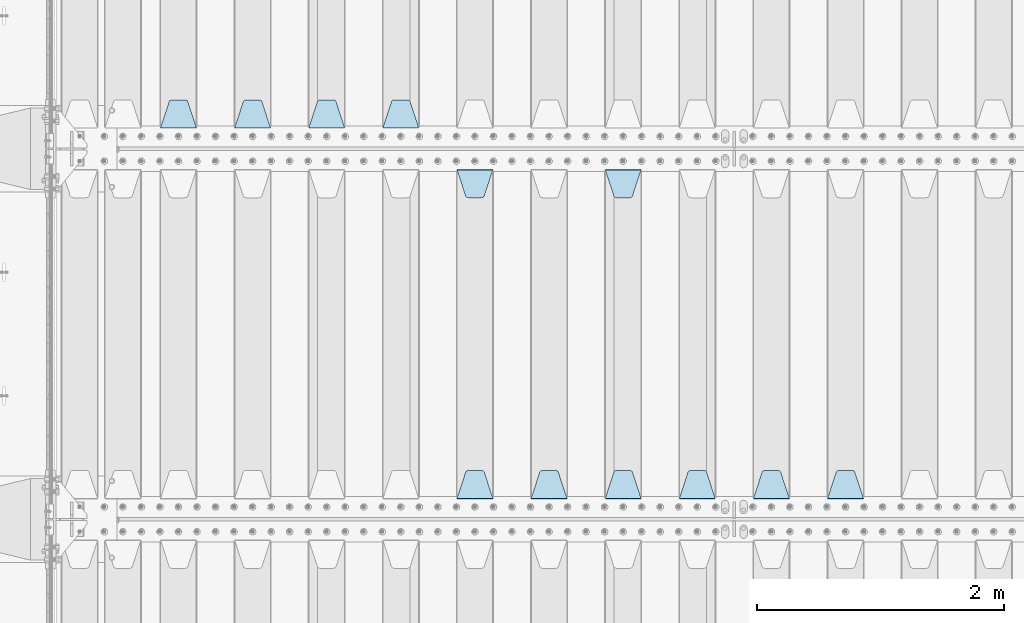
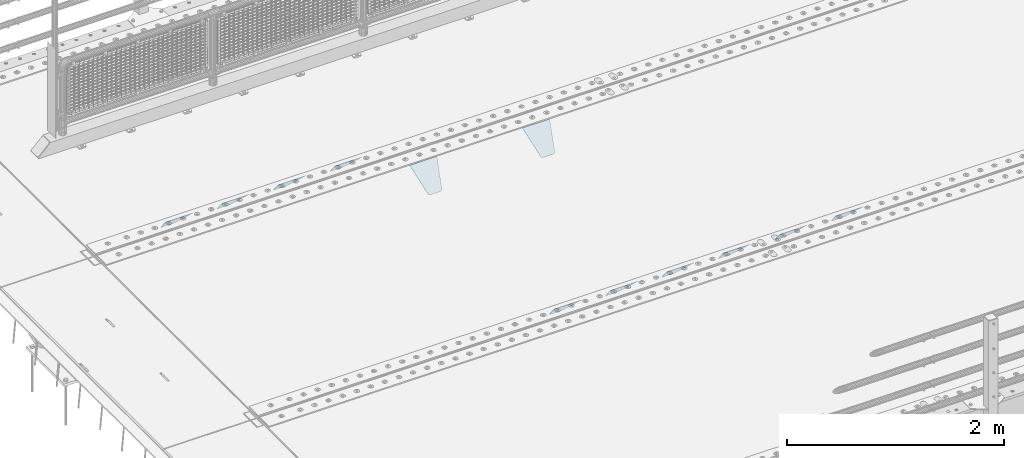
# One storey, part 201 of 247: 12 plates.
"""IFC2X3 building model written with IfcOpenShell, lengths in millimetres."""

from ifc_helpers import new_model, si_unit, frame, origin_with_axes, place, context, subcontext, project, spatial, faceted_brep, material, type_object, element, save


model = new_model("IFC2X3")

# Units and contexts
model_context = context("Model", 3, precision=1e-05, world=origin_with_axes())
body_context = subcontext(model_context, "Body", "Model", "MODEL_VIEW")
ifc_project = project(units=[si_unit("LENGTHUNIT", "METRE", prefix="MILLI"), si_unit("AREAUNIT", "SQUARE_METRE"), si_unit("VOLUMEUNIT", "CUBIC_METRE"), si_unit("MASSUNIT", "GRAM", prefix="KILO"), si_unit("TIMEUNIT", "SECOND"), si_unit("PLANEANGLEUNIT", "RADIAN"), si_unit("SOLIDANGLEUNIT", "STERADIAN"), si_unit("THERMODYNAMICTEMPERATUREUNIT", "DEGREE_CELSIUS"), si_unit("LUMINOUSINTENSITYUNIT", "LUMEN")], contexts=[model_context])

# Site, building, storey
site_placement = place(None, origin_with_axes())
site = spatial("IfcSite", under=ifc_project, at=site_placement, CompositionType="ELEMENT")
building_placement = place(site_placement, origin_with_axes())
building = spatial("IfcBuilding", under=site, at=building_placement, Name="Standard", CompositionType="ELEMENT")
storey_placement = place(building_placement, origin_with_axes())
storey = spatial("IfcBuildingStorey", under=building, at=storey_placement, Name="Undefined", CompositionType="ELEMENT", Elevation=0.0)

# Plates
ifc_material = material(Name="STEEL/S355N")
plate_type = type_object("IfcPlateType", PredefinedType="NOTDEFINED")
plate_1_placement = place(storey_placement, frame((6545.0, 3168.23223304703, -1.76776695296758), z_axis=(0.0, 0.707106781186548, -0.707106781186547), x_axis=(-1.0, 0.0, 0.0)))
element("IfcPlate", 1, at=plate_1_placement, inside=storey, type_object=plate_type, material=ifc_material, context=body_context, shape_type="Brep", body=[
    faceted_brep([(0.0, -2.49999999999909, 0.0), (69.345504679477, -2.5, 300.17173142483), (69.345504679477, 2.50000000000091, 300.171731424831), (0.0, 2.5, -9.09494701772928e-13), (70.9274061199576, -2.5, 304.897442415399), (70.9274061199576, 2.50000000000091, 304.8974424154), (73.3818627772307, -2.49999999999909, 309.234538108527), (73.3818627772307, 2.5, 309.234538108526), (76.6187032999551, -2.5, 313.023683126102), (76.6187032999551, 2.50000000000091, 313.023683126102), (80.5190132704993, -2.49999999999909, 316.125672595371), (80.5190132704993, 2.50000000000091, 316.125672595372), (84.9395038596849, -2.49999999999909, 318.426546230476), (84.9395038596849, 2.5, 318.426546230475), (89.7177759439219, -2.5, 319.841774983274), (89.7177759439219, 2.50000000000091, 319.841774983275), (94.678286292652, -2.5, 320.319366455077), (94.678286292652, 2.50000000000091, 320.319366455077), (195.321713707348, -2.5, 320.319366455077), (195.321713707348, 2.50000000000091, 320.319366455077), (200.282224056078, -2.5, 319.841774983274), (200.282224056078, 2.50000000000091, 319.841774983275), (205.060496140315, -2.5, 318.426546230475), (205.060496140315, 2.5, 318.426546230474), (209.480986729501, -2.49999999999818, 316.12567259537), (209.480986729501, 2.50000000000091, 316.12567259537), (213.381296700045, -2.5, 313.023683126101), (213.381296700045, 2.50000000000091, 313.023683126101), (216.618137222769, -2.5, 309.234538108525), (216.618137222769, 2.5, 309.234538108525), (219.072593880042, -2.49999999999909, 304.897442415398), (219.072593880042, 2.5, 304.897442415398), (220.654495320523, -2.5, 300.17173142483), (220.654495320523, 2.50000000000091, 300.171731424831), (290.0, -2.49999999999909, 0.0), (290.0, 2.5, -9.09494701772928e-13)], [[[0, 1, 2, 3]], [[1, 4, 5, 2]], [[4, 6, 7, 5]], [[6, 8, 9, 7]], [[8, 10, 11, 9]], [[10, 12, 13, 11]], [[12, 14, 15, 13]], [[14, 16, 17, 15]], [[16, 18, 19, 17]], [[18, 20, 21, 19]], [[20, 22, 23, 21]], [[22, 24, 25, 23]], [[24, 26, 27, 25]], [[26, 28, 29, 27]], [[28, 30, 31, 29]], [[30, 32, 33, 31]], [[32, 34, 35, 33]], [[34, 0, 3, 35]], [[5, 7, 9, 11, 13, 15, 17, 19, 21, 23, 25, 27, 29, 31, 33, 35, 3, 2]], [[34, 32, 30, 28, 26, 24, 22, 20, 18, 16, 14, 12, 10, 8, 6, 4, 1, 0]]]),
])
plate_2_placement = place(storey_placement, frame((5945.0, 3168.23223304703, -1.76776695296758), z_axis=(0.0, 0.707106781186548, -0.707106781186547), x_axis=(-1.0, 0.0, 0.0)))
element("IfcPlate", 2, at=plate_2_placement, inside=storey, type_object=plate_type, material=ifc_material, context=body_context, shape_type="Brep", body=[
    faceted_brep([(0.0, -2.49999999999909, 0.0), (69.345504679477, -2.5, 300.17173142483), (69.345504679477, 2.50000000000091, 300.171731424831), (0.0, 2.5, -9.09494701772928e-13), (70.9274061199576, -2.5, 304.897442415399), (70.9274061199576, 2.50000000000091, 304.8974424154), (73.3818627772307, -2.49999999999909, 309.234538108527), (73.3818627772307, 2.5, 309.234538108526), (76.6187032999551, -2.5, 313.023683126102), (76.6187032999551, 2.50000000000091, 313.023683126102), (80.5190132704993, -2.49999999999909, 316.125672595371), (80.5190132704993, 2.50000000000091, 316.125672595372), (84.9395038596849, -2.49999999999909, 318.426546230476), (84.9395038596849, 2.5, 318.426546230475), (89.7177759439219, -2.5, 319.841774983274), (89.7177759439219, 2.50000000000091, 319.841774983275), (94.678286292652, -2.5, 320.319366455077), (94.678286292652, 2.50000000000091, 320.319366455077), (195.321713707348, -2.5, 320.319366455077), (195.321713707348, 2.50000000000091, 320.319366455077), (200.282224056078, -2.5, 319.841774983274), (200.282224056078, 2.50000000000091, 319.841774983275), (205.060496140315, -2.5, 318.426546230475), (205.060496140315, 2.5, 318.426546230474), (209.480986729501, -2.49999999999818, 316.12567259537), (209.480986729501, 2.50000000000091, 316.12567259537), (213.381296700045, -2.5, 313.023683126101), (213.381296700045, 2.50000000000091, 313.023683126101), (216.618137222769, -2.5, 309.234538108525), (216.618137222769, 2.5, 309.234538108525), (219.072593880042, -2.49999999999909, 304.897442415398), (219.072593880042, 2.5, 304.897442415398), (220.654495320523, -2.5, 300.17173142483), (220.654495320523, 2.50000000000091, 300.171731424831), (290.0, -2.49999999999909, 0.0), (290.0, 2.5, -9.09494701772928e-13)], [[[0, 1, 2, 3]], [[1, 4, 5, 2]], [[4, 6, 7, 5]], [[6, 8, 9, 7]], [[8, 10, 11, 9]], [[10, 12, 13, 11]], [[12, 14, 15, 13]], [[14, 16, 17, 15]], [[16, 18, 19, 17]], [[18, 20, 21, 19]], [[20, 22, 23, 21]], [[22, 24, 25, 23]], [[24, 26, 27, 25]], [[26, 28, 29, 27]], [[28, 30, 31, 29]], [[30, 32, 33, 31]], [[32, 34, 35, 33]], [[34, 0, 3, 35]], [[5, 7, 9, 11, 13, 15, 17, 19, 21, 23, 25, 27, 29, 31, 33, 35, 3, 2]], [[34, 32, 30, 28, 26, 24, 22, 20, 18, 16, 14, 12, 10, 8, 6, 4, 1, 0]]]),
])
plate_3_placement = place(storey_placement, frame((5345.0, 3168.23223304703, -1.76776695296758), z_axis=(0.0, 0.707106781186548, -0.707106781186547), x_axis=(-1.0, 0.0, 0.0)))
element("IfcPlate", 3, at=plate_3_placement, inside=storey, type_object=plate_type, material=ifc_material, context=body_context, shape_type="Brep", body=[
    faceted_brep([(0.0, -2.49999999999909, 0.0), (69.345504679477, -2.5, 300.17173142483), (69.345504679477, 2.50000000000091, 300.171731424831), (0.0, 2.5, -9.09494701772928e-13), (70.9274061199576, -2.5, 304.897442415399), (70.9274061199576, 2.50000000000091, 304.8974424154), (73.3818627772307, -2.49999999999909, 309.234538108527), (73.3818627772307, 2.5, 309.234538108526), (76.6187032999551, -2.5, 313.023683126102), (76.6187032999551, 2.50000000000091, 313.023683126102), (80.5190132704993, -2.49999999999909, 316.125672595371), (80.5190132704993, 2.50000000000091, 316.125672595372), (84.9395038596849, -2.49999999999909, 318.426546230476), (84.9395038596849, 2.5, 318.426546230475), (89.7177759439219, -2.5, 319.841774983274), (89.7177759439219, 2.50000000000091, 319.841774983275), (94.678286292652, -2.5, 320.319366455077), (94.678286292652, 2.50000000000091, 320.319366455077), (195.321713707348, -2.5, 320.319366455077), (195.321713707348, 2.50000000000091, 320.319366455077), (200.282224056078, -2.5, 319.841774983274), (200.282224056078, 2.50000000000091, 319.841774983275), (205.060496140315, -2.5, 318.426546230475), (205.060496140315, 2.5, 318.426546230474), (209.480986729501, -2.49999999999818, 316.12567259537), (209.480986729501, 2.50000000000091, 316.12567259537), (213.381296700045, -2.5, 313.023683126101), (213.381296700045, 2.50000000000091, 313.023683126101), (216.618137222769, -2.5, 309.234538108525), (216.618137222769, 2.5, 309.234538108525), (219.072593880042, -2.49999999999909, 304.897442415398), (219.072593880042, 2.5, 304.897442415398), (220.654495320523, -2.5, 300.17173142483), (220.654495320523, 2.50000000000091, 300.171731424831), (290.0, -2.49999999999909, 0.0), (290.0, 2.5, -9.09494701772928e-13)], [[[0, 1, 2, 3]], [[1, 4, 5, 2]], [[4, 6, 7, 5]], [[6, 8, 9, 7]], [[8, 10, 11, 9]], [[10, 12, 13, 11]], [[12, 14, 15, 13]], [[14, 16, 17, 15]], [[16, 18, 19, 17]], [[18, 20, 21, 19]], [[20, 22, 23, 21]], [[22, 24, 25, 23]], [[24, 26, 27, 25]], [[26, 28, 29, 27]], [[28, 30, 31, 29]], [[30, 32, 33, 31]], [[32, 34, 35, 33]], [[34, 0, 3, 35]], [[5, 7, 9, 11, 13, 15, 17, 19, 21, 23, 25, 27, 29, 31, 33, 35, 3, 2]], [[34, 32, 30, 28, 26, 24, 22, 20, 18, 16, 14, 12, 10, 8, 6, 4, 1, 0]]]),
])
plate_4_placement = place(storey_placement, frame((4455.0, 5831.76776695594, -1.767766952965), z_axis=(0.0, -0.707106781186548, -0.707106781186547), x_axis=(1.0, 0.0, 0.0)))
element("IfcPlate", 4, at=plate_4_placement, inside=storey, type_object=plate_type, material=ifc_material, context=body_context, shape_type="Brep", body=[
    faceted_brep([(0.0, -2.49999999999909, 0.0), (69.345504679477, -2.5, 300.17173142483), (69.345504679477, 2.50000000000091, 300.171731424831), (0.0, 2.5, -9.09494701772928e-13), (70.9274061199576, -2.5, 304.897442415399), (70.9274061199576, 2.50000000000091, 304.8974424154), (73.3818627772307, -2.49999999999909, 309.234538108527), (73.3818627772307, 2.5, 309.234538108526), (76.6187032999551, -2.5, 313.023683126102), (76.6187032999551, 2.50000000000091, 313.023683126102), (80.5190132704993, -2.49999999999909, 316.125672595371), (80.5190132704993, 2.50000000000091, 316.125672595372), (84.9395038596849, -2.49999999999909, 318.426546230476), (84.9395038596849, 2.5, 318.426546230475), (89.7177759439219, -2.5, 319.841774983274), (89.7177759439219, 2.50000000000091, 319.841774983275), (94.678286292652, -2.5, 320.319366455077), (94.678286292652, 2.50000000000091, 320.319366455077), (195.321713707348, -2.5, 320.319366455077), (195.321713707348, 2.50000000000091, 320.319366455077), (200.282224056078, -2.5, 319.841774983274), (200.282224056078, 2.50000000000091, 319.841774983275), (205.060496140315, -2.5, 318.426546230475), (205.060496140315, 2.5, 318.426546230474), (209.480986729501, -2.49999999999818, 316.12567259537), (209.480986729501, 2.50000000000091, 316.12567259537), (213.381296700045, -2.5, 313.023683126101), (213.381296700045, 2.50000000000091, 313.023683126101), (216.618137222769, -2.5, 309.234538108525), (216.618137222769, 2.5, 309.234538108525), (219.072593880042, -2.49999999999909, 304.897442415398), (219.072593880042, 2.5, 304.897442415398), (220.654495320523, -2.5, 300.17173142483), (220.654495320523, 2.50000000000091, 300.171731424831), (290.0, -2.49999999999909, 0.0), (290.0, 2.5, -9.09494701772928e-13)], [[[0, 1, 2, 3]], [[1, 4, 5, 2]], [[4, 6, 7, 5]], [[6, 8, 9, 7]], [[8, 10, 11, 9]], [[10, 12, 13, 11]], [[12, 14, 15, 13]], [[14, 16, 17, 15]], [[16, 18, 19, 17]], [[18, 20, 21, 19]], [[20, 22, 23, 21]], [[22, 24, 25, 23]], [[24, 26, 27, 25]], [[26, 28, 29, 27]], [[28, 30, 31, 29]], [[30, 32, 33, 31]], [[32, 34, 35, 33]], [[34, 0, 3, 35]], [[5, 7, 9, 11, 13, 15, 17, 19, 21, 23, 25, 27, 29, 31, 33, 35, 3, 2]], [[34, 32, 30, 28, 26, 24, 22, 20, 18, 16, 14, 12, 10, 8, 6, 4, 1, 0]]]),
])
plate_5_placement = place(storey_placement, frame((4745.0, 3168.23223304703, -1.76776695296758), z_axis=(0.0, 0.707106781186548, -0.707106781186547), x_axis=(-1.0, 0.0, 0.0)))
element("IfcPlate", 5, at=plate_5_placement, inside=storey, type_object=plate_type, material=ifc_material, context=body_context, shape_type="Brep", body=[
    faceted_brep([(0.0, -2.49999999999909, 0.0), (69.345504679477, -2.5, 300.17173142483), (69.345504679477, 2.50000000000091, 300.171731424831), (0.0, 2.5, -9.09494701772928e-13), (70.9274061199576, -2.5, 304.897442415399), (70.9274061199576, 2.50000000000091, 304.8974424154), (73.3818627772307, -2.49999999999909, 309.234538108527), (73.3818627772307, 2.5, 309.234538108526), (76.6187032999551, -2.5, 313.023683126102), (76.6187032999551, 2.50000000000091, 313.023683126102), (80.5190132704993, -2.49999999999909, 316.125672595371), (80.5190132704993, 2.50000000000091, 316.125672595372), (84.9395038596849, -2.49999999999909, 318.426546230476), (84.9395038596849, 2.5, 318.426546230475), (89.7177759439219, -2.5, 319.841774983274), (89.7177759439219, 2.50000000000091, 319.841774983275), (94.678286292652, -2.5, 320.319366455077), (94.678286292652, 2.50000000000091, 320.319366455077), (195.321713707348, -2.5, 320.319366455077), (195.321713707348, 2.50000000000091, 320.319366455077), (200.282224056078, -2.5, 319.841774983274), (200.282224056078, 2.50000000000091, 319.841774983275), (205.060496140315, -2.5, 318.426546230475), (205.060496140315, 2.5, 318.426546230474), (209.480986729501, -2.49999999999818, 316.12567259537), (209.480986729501, 2.50000000000091, 316.12567259537), (213.381296700045, -2.5, 313.023683126101), (213.381296700045, 2.50000000000091, 313.023683126101), (216.618137222769, -2.5, 309.234538108525), (216.618137222769, 2.5, 309.234538108525), (219.072593880042, -2.49999999999909, 304.897442415398), (219.072593880042, 2.5, 304.897442415398), (220.654495320523, -2.5, 300.17173142483), (220.654495320523, 2.50000000000091, 300.171731424831), (290.0, -2.49999999999909, 0.0), (290.0, 2.5, -9.09494701772928e-13)], [[[0, 1, 2, 3]], [[1, 4, 5, 2]], [[4, 6, 7, 5]], [[6, 8, 9, 7]], [[8, 10, 11, 9]], [[10, 12, 13, 11]], [[12, 14, 15, 13]], [[14, 16, 17, 15]], [[16, 18, 19, 17]], [[18, 20, 21, 19]], [[20, 22, 23, 21]], [[22, 24, 25, 23]], [[24, 26, 27, 25]], [[26, 28, 29, 27]], [[28, 30, 31, 29]], [[30, 32, 33, 31]], [[32, 34, 35, 33]], [[34, 0, 3, 35]], [[5, 7, 9, 11, 13, 15, 17, 19, 21, 23, 25, 27, 29, 31, 33, 35, 3, 2]], [[34, 32, 30, 28, 26, 24, 22, 20, 18, 16, 14, 12, 10, 8, 6, 4, 1, 0]]]),
])
plate_6_placement = place(storey_placement, frame((4145.0, 3168.23223304703, -1.76776695296758), z_axis=(0.0, 0.707106781186548, -0.707106781186547), x_axis=(-1.0, 0.0, 0.0)))
element("IfcPlate", 6, at=plate_6_placement, inside=storey, type_object=plate_type, material=ifc_material, context=body_context, shape_type="Brep", body=[
    faceted_brep([(0.0, -2.49999999999909, 0.0), (69.345504679477, -2.5, 300.17173142483), (69.345504679477, 2.50000000000091, 300.171731424831), (0.0, 2.5, -9.09494701772928e-13), (70.9274061199576, -2.5, 304.897442415399), (70.9274061199576, 2.50000000000091, 304.8974424154), (73.3818627772307, -2.49999999999909, 309.234538108527), (73.3818627772307, 2.5, 309.234538108526), (76.6187032999551, -2.5, 313.023683126102), (76.6187032999551, 2.50000000000091, 313.023683126102), (80.5190132704993, -2.49999999999909, 316.125672595371), (80.5190132704993, 2.50000000000091, 316.125672595372), (84.9395038596849, -2.49999999999909, 318.426546230476), (84.9395038596849, 2.5, 318.426546230475), (89.7177759439219, -2.5, 319.841774983274), (89.7177759439219, 2.50000000000091, 319.841774983275), (94.678286292652, -2.5, 320.319366455077), (94.678286292652, 2.50000000000091, 320.319366455077), (195.321713707348, -2.5, 320.319366455077), (195.321713707348, 2.50000000000091, 320.319366455077), (200.282224056078, -2.5, 319.841774983274), (200.282224056078, 2.50000000000091, 319.841774983275), (205.060496140315, -2.5, 318.426546230475), (205.060496140315, 2.5, 318.426546230474), (209.480986729501, -2.49999999999818, 316.12567259537), (209.480986729501, 2.50000000000091, 316.12567259537), (213.381296700045, -2.5, 313.023683126101), (213.381296700045, 2.50000000000091, 313.023683126101), (216.618137222769, -2.5, 309.234538108525), (216.618137222769, 2.5, 309.234538108525), (219.072593880042, -2.49999999999909, 304.897442415398), (219.072593880042, 2.5, 304.897442415398), (220.654495320523, -2.5, 300.17173142483), (220.654495320523, 2.50000000000091, 300.171731424831), (290.0, -2.49999999999909, 0.0), (290.0, 2.5, -9.09494701772928e-13)], [[[0, 1, 2, 3]], [[1, 4, 5, 2]], [[4, 6, 7, 5]], [[6, 8, 9, 7]], [[8, 10, 11, 9]], [[10, 12, 13, 11]], [[12, 14, 15, 13]], [[14, 16, 17, 15]], [[16, 18, 19, 17]], [[18, 20, 21, 19]], [[20, 22, 23, 21]], [[22, 24, 25, 23]], [[24, 26, 27, 25]], [[26, 28, 29, 27]], [[28, 30, 31, 29]], [[30, 32, 33, 31]], [[32, 34, 35, 33]], [[34, 0, 3, 35]], [[5, 7, 9, 11, 13, 15, 17, 19, 21, 23, 25, 27, 29, 31, 33, 35, 3, 2]], [[34, 32, 30, 28, 26, 24, 22, 20, 18, 16, 14, 12, 10, 8, 6, 4, 1, 0]]]),
])
plate_7_placement = place(storey_placement, frame((3255.0, 5831.76776695594, -1.767766952965), z_axis=(0.0, -0.707106781186548, -0.707106781186547), x_axis=(1.0, 0.0, 0.0)))
element("IfcPlate", 7, at=plate_7_placement, inside=storey, type_object=plate_type, material=ifc_material, context=body_context, shape_type="Brep", body=[
    faceted_brep([(0.0, -2.49999999999909, 0.0), (69.345504679477, -2.5, 300.17173142483), (69.345504679477, 2.50000000000091, 300.171731424831), (0.0, 2.5, -9.09494701772928e-13), (70.9274061199576, -2.5, 304.897442415399), (70.9274061199576, 2.50000000000091, 304.8974424154), (73.3818627772307, -2.49999999999909, 309.234538108527), (73.3818627772307, 2.5, 309.234538108526), (76.6187032999551, -2.5, 313.023683126102), (76.6187032999551, 2.50000000000091, 313.023683126102), (80.5190132704993, -2.49999999999909, 316.125672595371), (80.5190132704993, 2.50000000000091, 316.125672595372), (84.9395038596849, -2.49999999999909, 318.426546230476), (84.9395038596849, 2.5, 318.426546230475), (89.7177759439219, -2.5, 319.841774983274), (89.7177759439219, 2.50000000000091, 319.841774983275), (94.678286292652, -2.5, 320.319366455077), (94.678286292652, 2.50000000000091, 320.319366455077), (195.321713707348, -2.5, 320.319366455077), (195.321713707348, 2.50000000000091, 320.319366455077), (200.282224056078, -2.5, 319.841774983274), (200.282224056078, 2.50000000000091, 319.841774983275), (205.060496140315, -2.5, 318.426546230475), (205.060496140315, 2.5, 318.426546230474), (209.480986729501, -2.49999999999818, 316.12567259537), (209.480986729501, 2.50000000000091, 316.12567259537), (213.381296700045, -2.5, 313.023683126101), (213.381296700045, 2.50000000000091, 313.023683126101), (216.618137222769, -2.5, 309.234538108525), (216.618137222769, 2.5, 309.234538108525), (219.072593880042, -2.49999999999909, 304.897442415398), (219.072593880042, 2.5, 304.897442415398), (220.654495320523, -2.5, 300.17173142483), (220.654495320523, 2.50000000000091, 300.171731424831), (290.0, -2.49999999999909, 0.0), (290.0, 2.5, -9.09494701772928e-13)], [[[0, 1, 2, 3]], [[1, 4, 5, 2]], [[4, 6, 7, 5]], [[6, 8, 9, 7]], [[8, 10, 11, 9]], [[10, 12, 13, 11]], [[12, 14, 15, 13]], [[14, 16, 17, 15]], [[16, 18, 19, 17]], [[18, 20, 21, 19]], [[20, 22, 23, 21]], [[22, 24, 25, 23]], [[24, 26, 27, 25]], [[26, 28, 29, 27]], [[28, 30, 31, 29]], [[30, 32, 33, 31]], [[32, 34, 35, 33]], [[34, 0, 3, 35]], [[5, 7, 9, 11, 13, 15, 17, 19, 21, 23, 25, 27, 29, 31, 33, 35, 3, 2]], [[34, 32, 30, 28, 26, 24, 22, 20, 18, 16, 14, 12, 10, 8, 6, 4, 1, 0]]]),
])
plate_8_placement = place(storey_placement, frame((3545.0, 3168.23223304703, -1.76776695296758), z_axis=(0.0, 0.707106781186548, -0.707106781186547), x_axis=(-1.0, 0.0, 0.0)))
element("IfcPlate", 8, at=plate_8_placement, inside=storey, type_object=plate_type, material=ifc_material, context=body_context, shape_type="Brep", body=[
    faceted_brep([(0.0, -2.49999999999909, 0.0), (69.345504679477, -2.5, 300.17173142483), (69.345504679477, 2.50000000000091, 300.171731424831), (0.0, 2.5, -9.09494701772928e-13), (70.9274061199576, -2.5, 304.897442415399), (70.9274061199576, 2.50000000000091, 304.8974424154), (73.3818627772307, -2.49999999999909, 309.234538108527), (73.3818627772307, 2.5, 309.234538108526), (76.6187032999551, -2.5, 313.023683126102), (76.6187032999551, 2.50000000000091, 313.023683126102), (80.5190132704993, -2.49999999999909, 316.125672595371), (80.5190132704993, 2.50000000000091, 316.125672595372), (84.9395038596849, -2.49999999999909, 318.426546230476), (84.9395038596849, 2.5, 318.426546230475), (89.7177759439219, -2.5, 319.841774983274), (89.7177759439219, 2.50000000000091, 319.841774983275), (94.678286292652, -2.5, 320.319366455077), (94.678286292652, 2.50000000000091, 320.319366455077), (195.321713707348, -2.5, 320.319366455077), (195.321713707348, 2.50000000000091, 320.319366455077), (200.282224056078, -2.5, 319.841774983274), (200.282224056078, 2.50000000000091, 319.841774983275), (205.060496140315, -2.5, 318.426546230475), (205.060496140315, 2.5, 318.426546230474), (209.480986729501, -2.49999999999818, 316.12567259537), (209.480986729501, 2.50000000000091, 316.12567259537), (213.381296700045, -2.5, 313.023683126101), (213.381296700045, 2.50000000000091, 313.023683126101), (216.618137222769, -2.5, 309.234538108525), (216.618137222769, 2.5, 309.234538108525), (219.072593880042, -2.49999999999909, 304.897442415398), (219.072593880042, 2.5, 304.897442415398), (220.654495320523, -2.5, 300.17173142483), (220.654495320523, 2.50000000000091, 300.171731424831), (290.0, -2.49999999999909, 0.0), (290.0, 2.5, -9.09494701772928e-13)], [[[0, 1, 2, 3]], [[1, 4, 5, 2]], [[4, 6, 7, 5]], [[6, 8, 9, 7]], [[8, 10, 11, 9]], [[10, 12, 13, 11]], [[12, 14, 15, 13]], [[14, 16, 17, 15]], [[16, 18, 19, 17]], [[18, 20, 21, 19]], [[20, 22, 23, 21]], [[22, 24, 25, 23]], [[24, 26, 27, 25]], [[26, 28, 29, 27]], [[28, 30, 31, 29]], [[30, 32, 33, 31]], [[32, 34, 35, 33]], [[34, 0, 3, 35]], [[5, 7, 9, 11, 13, 15, 17, 19, 21, 23, 25, 27, 29, 31, 33, 35, 3, 2]], [[34, 32, 30, 28, 26, 24, 22, 20, 18, 16, 14, 12, 10, 8, 6, 4, 1, 0]]]),
])
plate_9_placement = place(storey_placement, frame((2945.0, 6168.23223304703, -1.76776695296758), z_axis=(0.0, 0.707106781186548, -0.707106781186547), x_axis=(-1.0, 0.0, 0.0)))
element("IfcPlate", 9, at=plate_9_placement, inside=storey, type_object=plate_type, material=ifc_material, context=body_context, shape_type="Brep", body=[
    faceted_brep([(0.0, -2.49999999999909, 0.0), (69.345504679477, -2.5, 300.17173142483), (69.345504679477, 2.50000000000091, 300.171731424831), (0.0, 2.5, -9.09494701772928e-13), (70.9274061199576, -2.5, 304.897442415399), (70.9274061199576, 2.50000000000091, 304.8974424154), (73.3818627772307, -2.49999999999909, 309.234538108527), (73.3818627772307, 2.5, 309.234538108526), (76.6187032999551, -2.5, 313.023683126102), (76.6187032999551, 2.50000000000091, 313.023683126102), (80.5190132704993, -2.49999999999909, 316.125672595371), (80.5190132704993, 2.50000000000091, 316.125672595372), (84.9395038596849, -2.49999999999909, 318.426546230476), (84.9395038596849, 2.5, 318.426546230475), (89.7177759439219, -2.5, 319.841774983274), (89.7177759439219, 2.50000000000091, 319.841774983275), (94.678286292652, -2.5, 320.319366455077), (94.678286292652, 2.50000000000091, 320.319366455077), (195.321713707348, -2.5, 320.319366455077), (195.321713707348, 2.50000000000091, 320.319366455077), (200.282224056078, -2.5, 319.841774983274), (200.282224056078, 2.50000000000091, 319.841774983275), (205.060496140315, -2.5, 318.426546230475), (205.060496140315, 2.5, 318.426546230474), (209.480986729501, -2.49999999999818, 316.12567259537), (209.480986729501, 2.50000000000091, 316.12567259537), (213.381296700045, -2.5, 313.023683126101), (213.381296700045, 2.50000000000091, 313.023683126101), (216.618137222769, -2.5, 309.234538108525), (216.618137222769, 2.5, 309.234538108525), (219.072593880042, -2.49999999999909, 304.897442415398), (219.072593880042, 2.5, 304.897442415398), (220.654495320523, -2.5, 300.17173142483), (220.654495320523, 2.50000000000091, 300.171731424831), (290.0, -2.49999999999909, 0.0), (290.0, 2.5, -9.09494701772928e-13)], [[[0, 1, 2, 3]], [[1, 4, 5, 2]], [[4, 6, 7, 5]], [[6, 8, 9, 7]], [[8, 10, 11, 9]], [[10, 12, 13, 11]], [[12, 14, 15, 13]], [[14, 16, 17, 15]], [[16, 18, 19, 17]], [[18, 20, 21, 19]], [[20, 22, 23, 21]], [[22, 24, 25, 23]], [[24, 26, 27, 25]], [[26, 28, 29, 27]], [[28, 30, 31, 29]], [[30, 32, 33, 31]], [[32, 34, 35, 33]], [[34, 0, 3, 35]], [[5, 7, 9, 11, 13, 15, 17, 19, 21, 23, 25, 27, 29, 31, 33, 35, 3, 2]], [[34, 32, 30, 28, 26, 24, 22, 20, 18, 16, 14, 12, 10, 8, 6, 4, 1, 0]]]),
])
plate_10_placement = place(storey_placement, frame((2345.0, 6168.23223304703, -1.76776695296758), z_axis=(0.0, 0.707106781186548, -0.707106781186547), x_axis=(-1.0, 0.0, 0.0)))
element("IfcPlate", 10, at=plate_10_placement, inside=storey, type_object=plate_type, material=ifc_material, context=body_context, shape_type="Brep", body=[
    faceted_brep([(0.0, -2.49999999999909, 0.0), (69.345504679477, -2.5, 300.17173142483), (69.345504679477, 2.50000000000091, 300.171731424831), (0.0, 2.5, -9.09494701772928e-13), (70.9274061199576, -2.5, 304.897442415399), (70.9274061199576, 2.50000000000091, 304.8974424154), (73.3818627772307, -2.49999999999909, 309.234538108527), (73.3818627772307, 2.5, 309.234538108526), (76.6187032999551, -2.5, 313.023683126102), (76.6187032999551, 2.50000000000091, 313.023683126102), (80.5190132704993, -2.49999999999909, 316.125672595371), (80.5190132704993, 2.50000000000091, 316.125672595372), (84.9395038596849, -2.49999999999909, 318.426546230476), (84.9395038596849, 2.5, 318.426546230475), (89.7177759439219, -2.5, 319.841774983274), (89.7177759439219, 2.50000000000091, 319.841774983275), (94.678286292652, -2.5, 320.319366455077), (94.678286292652, 2.50000000000091, 320.319366455077), (195.321713707348, -2.5, 320.319366455077), (195.321713707348, 2.50000000000091, 320.319366455077), (200.282224056078, -2.5, 319.841774983274), (200.282224056078, 2.50000000000091, 319.841774983275), (205.060496140315, -2.5, 318.426546230475), (205.060496140315, 2.5, 318.426546230474), (209.480986729501, -2.49999999999818, 316.12567259537), (209.480986729501, 2.50000000000091, 316.12567259537), (213.381296700045, -2.5, 313.023683126101), (213.381296700045, 2.50000000000091, 313.023683126101), (216.618137222769, -2.5, 309.234538108525), (216.618137222769, 2.5, 309.234538108525), (219.072593880042, -2.49999999999909, 304.897442415398), (219.072593880042, 2.5, 304.897442415398), (220.654495320523, -2.5, 300.17173142483), (220.654495320523, 2.50000000000091, 300.171731424831), (290.0, -2.49999999999909, 0.0), (290.0, 2.5, -9.09494701772928e-13)], [[[0, 1, 2, 3]], [[1, 4, 5, 2]], [[4, 6, 7, 5]], [[6, 8, 9, 7]], [[8, 10, 11, 9]], [[10, 12, 13, 11]], [[12, 14, 15, 13]], [[14, 16, 17, 15]], [[16, 18, 19, 17]], [[18, 20, 21, 19]], [[20, 22, 23, 21]], [[22, 24, 25, 23]], [[24, 26, 27, 25]], [[26, 28, 29, 27]], [[28, 30, 31, 29]], [[30, 32, 33, 31]], [[32, 34, 35, 33]], [[34, 0, 3, 35]], [[5, 7, 9, 11, 13, 15, 17, 19, 21, 23, 25, 27, 29, 31, 33, 35, 3, 2]], [[34, 32, 30, 28, 26, 24, 22, 20, 18, 16, 14, 12, 10, 8, 6, 4, 1, 0]]]),
])
plate_11_placement = place(storey_placement, frame((1745.0, 6168.23223304703, -1.76776695296758), z_axis=(0.0, 0.707106781186548, -0.707106781186547), x_axis=(-1.0, 0.0, 0.0)))
element("IfcPlate", 11, at=plate_11_placement, inside=storey, type_object=plate_type, material=ifc_material, context=body_context, shape_type="Brep", body=[
    faceted_brep([(0.0, -2.49999999999909, 0.0), (69.345504679477, -2.5, 300.17173142483), (69.345504679477, 2.50000000000091, 300.171731424831), (0.0, 2.5, -9.09494701772928e-13), (70.9274061199576, -2.5, 304.897442415399), (70.9274061199576, 2.50000000000091, 304.8974424154), (73.3818627772307, -2.49999999999909, 309.234538108527), (73.3818627772307, 2.5, 309.234538108526), (76.6187032999551, -2.5, 313.023683126102), (76.6187032999551, 2.50000000000091, 313.023683126102), (80.5190132704993, -2.49999999999909, 316.125672595371), (80.5190132704993, 2.50000000000091, 316.125672595372), (84.9395038596849, -2.49999999999909, 318.426546230476), (84.9395038596849, 2.5, 318.426546230475), (89.7177759439219, -2.5, 319.841774983274), (89.7177759439219, 2.50000000000091, 319.841774983275), (94.678286292652, -2.5, 320.319366455077), (94.678286292652, 2.50000000000091, 320.319366455077), (195.321713707348, -2.5, 320.319366455077), (195.321713707348, 2.50000000000091, 320.319366455077), (200.282224056078, -2.5, 319.841774983274), (200.282224056078, 2.50000000000091, 319.841774983275), (205.060496140315, -2.5, 318.426546230475), (205.060496140315, 2.5, 318.426546230474), (209.480986729501, -2.49999999999818, 316.12567259537), (209.480986729501, 2.50000000000091, 316.12567259537), (213.381296700045, -2.5, 313.023683126101), (213.381296700045, 2.50000000000091, 313.023683126101), (216.618137222769, -2.5, 309.234538108525), (216.618137222769, 2.5, 309.234538108525), (219.072593880042, -2.49999999999909, 304.897442415398), (219.072593880042, 2.5, 304.897442415398), (220.654495320523, -2.5, 300.17173142483), (220.654495320523, 2.50000000000091, 300.171731424831), (290.0, -2.49999999999909, 0.0), (290.0, 2.5, -9.09494701772928e-13)], [[[0, 1, 2, 3]], [[1, 4, 5, 2]], [[4, 6, 7, 5]], [[6, 8, 9, 7]], [[8, 10, 11, 9]], [[10, 12, 13, 11]], [[12, 14, 15, 13]], [[14, 16, 17, 15]], [[16, 18, 19, 17]], [[18, 20, 21, 19]], [[20, 22, 23, 21]], [[22, 24, 25, 23]], [[24, 26, 27, 25]], [[26, 28, 29, 27]], [[28, 30, 31, 29]], [[30, 32, 33, 31]], [[32, 34, 35, 33]], [[34, 0, 3, 35]], [[5, 7, 9, 11, 13, 15, 17, 19, 21, 23, 25, 27, 29, 31, 33, 35, 3, 2]], [[34, 32, 30, 28, 26, 24, 22, 20, 18, 16, 14, 12, 10, 8, 6, 4, 1, 0]]]),
])
plate_12_placement = place(storey_placement, frame((1145.0, 6168.23223304703, -1.76776695296758), z_axis=(0.0, 0.707106781186548, -0.707106781186547), x_axis=(-1.0, 0.0, 0.0)))
element("IfcPlate", 12, at=plate_12_placement, inside=storey, type_object=plate_type, material=ifc_material, context=body_context, shape_type="Brep", body=[
    faceted_brep([(0.0, -2.49999999999909, 0.0), (69.345504679477, -2.5, 300.17173142483), (69.345504679477, 2.50000000000091, 300.171731424831), (0.0, 2.5, -9.09494701772928e-13), (70.9274061199576, -2.5, 304.897442415399), (70.9274061199576, 2.50000000000091, 304.8974424154), (73.3818627772307, -2.49999999999909, 309.234538108527), (73.3818627772307, 2.5, 309.234538108526), (76.6187032999551, -2.5, 313.023683126102), (76.6187032999551, 2.50000000000091, 313.023683126102), (80.5190132704993, -2.49999999999909, 316.125672595371), (80.5190132704993, 2.50000000000091, 316.125672595372), (84.9395038596849, -2.49999999999909, 318.426546230476), (84.9395038596849, 2.5, 318.426546230475), (89.7177759439219, -2.5, 319.841774983274), (89.7177759439219, 2.50000000000091, 319.841774983275), (94.678286292652, -2.5, 320.319366455077), (94.678286292652, 2.50000000000091, 320.319366455077), (195.321713707348, -2.5, 320.319366455077), (195.321713707348, 2.50000000000091, 320.319366455077), (200.282224056078, -2.5, 319.841774983274), (200.282224056078, 2.50000000000091, 319.841774983275), (205.060496140315, -2.5, 318.426546230475), (205.060496140315, 2.5, 318.426546230474), (209.480986729501, -2.49999999999818, 316.12567259537), (209.480986729501, 2.50000000000091, 316.12567259537), (213.381296700045, -2.5, 313.023683126101), (213.381296700045, 2.50000000000091, 313.023683126101), (216.618137222769, -2.5, 309.234538108525), (216.618137222769, 2.5, 309.234538108525), (219.072593880042, -2.49999999999909, 304.897442415398), (219.072593880042, 2.5, 304.897442415398), (220.654495320523, -2.5, 300.17173142483), (220.654495320523, 2.50000000000091, 300.171731424831), (290.0, -2.49999999999909, 0.0), (290.0, 2.5, -9.09494701772928e-13)], [[[0, 1, 2, 3]], [[1, 4, 5, 2]], [[4, 6, 7, 5]], [[6, 8, 9, 7]], [[8, 10, 11, 9]], [[10, 12, 13, 11]], [[12, 14, 15, 13]], [[14, 16, 17, 15]], [[16, 18, 19, 17]], [[18, 20, 21, 19]], [[20, 22, 23, 21]], [[22, 24, 25, 23]], [[24, 26, 27, 25]], [[26, 28, 29, 27]], [[28, 30, 31, 29]], [[30, 32, 33, 31]], [[32, 34, 35, 33]], [[34, 0, 3, 35]], [[5, 7, 9, 11, 13, 15, 17, 19, 21, 23, 25, 27, 29, 31, 33, 35, 3, 2]], [[34, 32, 30, 28, 26, 24, 22, 20, 18, 16, 14, 12, 10, 8, 6, 4, 1, 0]]]),
])

save(model, "model.ifc")
